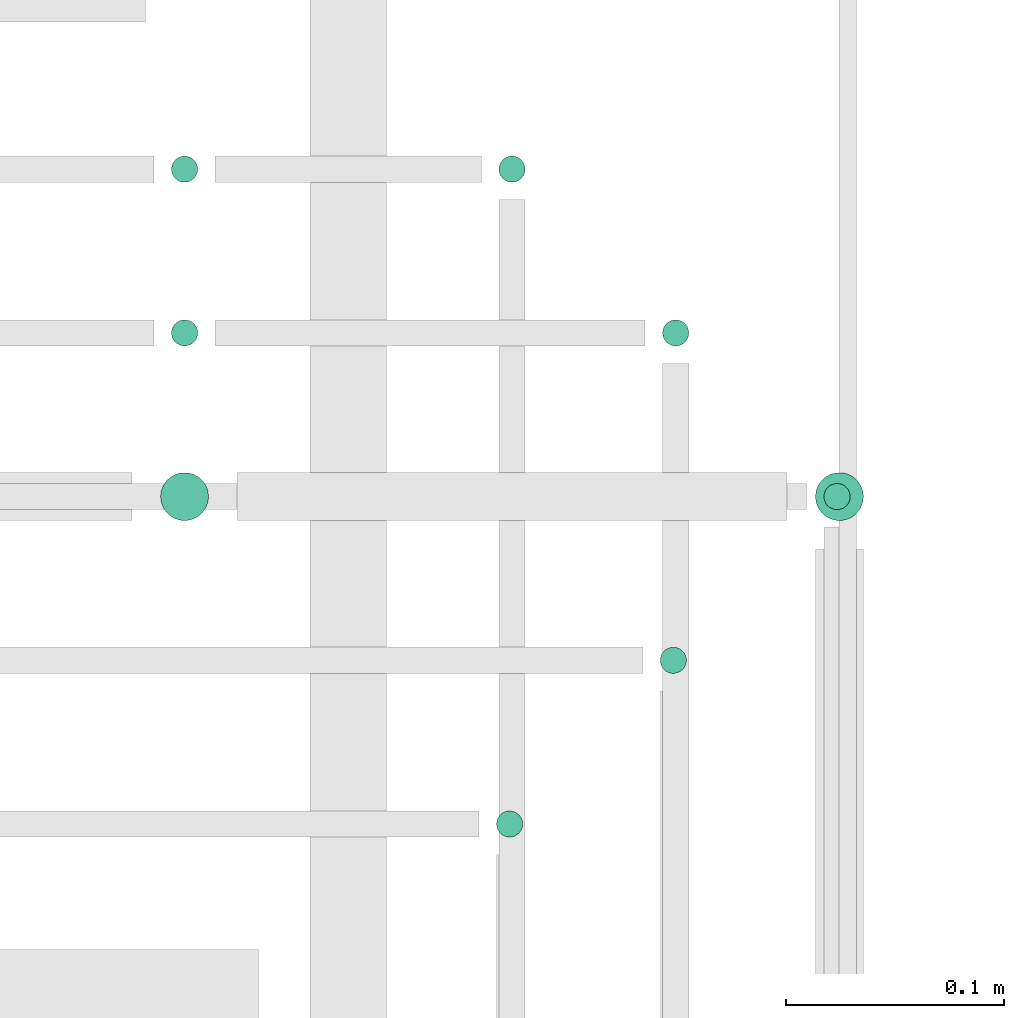
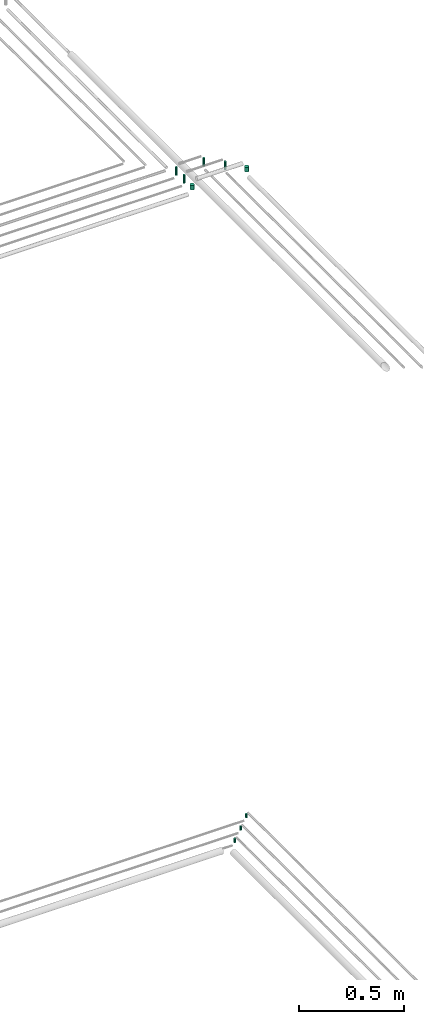
# One storey, part 317 of 331: 9 flow segments.
"""IFC2X3 building model written with IfcOpenShell, lengths in millimetres."""

from ifc_helpers import new_model, entity, si_unit, converted_unit, derived_unit, direction, frame, frame_2d, origin, origin_2d_with_axis, place, context, subcontext, project, spatial, circle, extrude, type_object, element, save


model = new_model("IFC2X3")

# Units and contexts
model_context = context("Model", 3, precision=0.01, world=origin(), true_north=direction((6.12303176911189e-17, 1.0)))
body_context = subcontext(model_context, "Body", "Model", "MODEL_VIEW")
ifc_project = project(units=[si_unit("LENGTHUNIT", "METRE", prefix="MILLI"), si_unit("AREAUNIT", "SQUARE_METRE"), si_unit("VOLUMEUNIT", "CUBIC_METRE"), converted_unit("PLANEANGLEUNIT", "DEGREE", entity("IfcRatioMeasure", 0.0174532925199433), si_unit("PLANEANGLEUNIT", "RADIAN"), dimensions=[0, 0, 0, 0, 0, 0, 0]), si_unit("MASSUNIT", "GRAM", prefix="KILO"), derived_unit("MASSDENSITYUNIT", [(si_unit("MASSUNIT", "GRAM", prefix="KILO"), 1), (si_unit("LENGTHUNIT", "METRE"), -3)]), derived_unit("MOMENTOFINERTIAUNIT", [(si_unit("LENGTHUNIT", "METRE"), 4)]), si_unit("TIMEUNIT", "SECOND"), si_unit("FREQUENCYUNIT", "HERTZ"), si_unit("THERMODYNAMICTEMPERATUREUNIT", "DEGREE_CELSIUS"), derived_unit("THERMALTRANSMITTANCEUNIT", [(si_unit("MASSUNIT", "GRAM", prefix="KILO"), 1), (si_unit("THERMODYNAMICTEMPERATUREUNIT", "KELVIN"), -1), (si_unit("TIMEUNIT", "SECOND"), -3)]), derived_unit("VOLUMETRICFLOWRATEUNIT", [(si_unit("LENGTHUNIT", "METRE"), 3), (si_unit("TIMEUNIT", "SECOND"), -1)]), derived_unit("MASSFLOWRATEUNIT", [(si_unit("MASSUNIT", "GRAM", prefix="KILO"), 1), (si_unit("TIMEUNIT", "SECOND"), -1)]), derived_unit("ROTATIONALFREQUENCYUNIT", [(si_unit("TIMEUNIT", "SECOND"), -1)]), si_unit("ELECTRICCURRENTUNIT", "AMPERE"), si_unit("ELECTRICVOLTAGEUNIT", "VOLT"), si_unit("POWERUNIT", "WATT"), si_unit("FORCEUNIT", "NEWTON", prefix="KILO"), si_unit("ILLUMINANCEUNIT", "LUX"), si_unit("LUMINOUSFLUXUNIT", "LUMEN"), si_unit("LUMINOUSINTENSITYUNIT", "CANDELA"), derived_unit("USERDEFINED", [(si_unit("MASSUNIT", "GRAM", prefix="KILO"), -1), (si_unit("LENGTHUNIT", "METRE"), -2), (si_unit("TIMEUNIT", "SECOND"), 3), (si_unit("LUMINOUSFLUXUNIT", "LUMEN"), 1)]), derived_unit("LINEARVELOCITYUNIT", [(si_unit("LENGTHUNIT", "METRE"), 1), (si_unit("TIMEUNIT", "SECOND"), -1)]), si_unit("PRESSUREUNIT", "PASCAL"), derived_unit("USERDEFINED", [(si_unit("LENGTHUNIT", "METRE"), -2), (si_unit("MASSUNIT", "GRAM", prefix="KILO"), 1), (si_unit("TIMEUNIT", "SECOND"), -2)]), derived_unit("LINEARFORCEUNIT", [(si_unit("MASSUNIT", "GRAM", prefix="KILO"), 1), (si_unit("LENGTHUNIT", "METRE"), 1), (si_unit("TIMEUNIT", "SECOND"), -2), (si_unit("LENGTHUNIT", "METRE"), -1)]), derived_unit("PLANARFORCEUNIT", [(si_unit("MASSUNIT", "GRAM", prefix="KILO"), 1), (si_unit("LENGTHUNIT", "METRE"), 1), (si_unit("TIMEUNIT", "SECOND"), -2), (si_unit("LENGTHUNIT", "METRE"), -2)])], contexts=[model_context])

# Site, building, storey
site_placement = place(None, frame((0.0, -0.00077364408347762, 0.0)))
site = spatial("IfcSite", under=ifc_project, at=site_placement, CompositionType="ELEMENT")
building_placement = place(site_placement, origin())
building = spatial("IfcBuilding", under=site, at=building_placement, CompositionType="ELEMENT")
storey_placement = place(building_placement, origin())
storey = spatial("IfcBuildingStorey", under=building, at=storey_placement, CompositionType="ELEMENT", Elevation=0.0)

# Flow segments
pipe_segment_type = type_object("IfcPipeSegmentType", PredefinedType="NOTDEFINED")
flow_segment_1_placement = place(storey_placement, frame((62062.513259057, 14117.4047277641, 14714.0)))
element("IfcFlowSegment", 1, at=flow_segment_1_placement, inside=storey, type_object=pipe_segment_type, context=body_context, shape_type="SweptSolid", body=[
    extrude(circle(Radius=6.0, at=frame_2d((0.0, -2.16573425859679e-12), x_axis=(1.0, 0.0))), frame((7.59527223591454, 7.59527223591887, 0.0)), (0.0, 0.0, 1.0), 22.000000000008),
])
flow_segment_2_placement = place(storey_placement, frame((62137.513259057, 14192.4047277641, 14714.0)))
element("IfcFlowSegment", 2, at=flow_segment_2_placement, inside=storey, type_object=pipe_segment_type, context=body_context, shape_type="SweptSolid", body=[
    extrude(circle(Radius=6.0, at=origin_2d_with_axis()), frame((7.59527223591454, 7.5952722359167, 0.0)), (0.0, 0.0, 1.0), 22.000000000008),
])
flow_segment_3_placement = place(storey_placement, frame((62212.5132590569, 14267.4047277641, 14714.0)))
element("IfcFlowSegment", 3, at=flow_segment_3_placement, inside=storey, type_object=pipe_segment_type, context=body_context, shape_type="SweptSolid", body=[
    extrude(circle(Radius=6.0, at=origin_2d_with_axis()), frame((7.59527223591454, 7.5952722359167, 0.0)), (0.0, 0.0, 1.0), 22.0000000000015),
])
flow_segment_4_placement = place(storey_placement, frame((62208.5947663298, 14262.4047277641, 18474.0)))
element("IfcFlowSegment", 4, at=flow_segment_4_placement, inside=storey, type_object=pipe_segment_type, context=body_context, shape_type="SweptSolid", body=[
    extrude(circle(Radius=11.0, at=origin_2d_with_axis()), frame((12.5952722359134, 12.5952722359156, 0.0), z_axis=(0.0, 0.0, 1.0), x_axis=(-1.0, 0.0, 0.0)), (0.0, 0.0, 1.0), 27.0000000000935),
])
flow_segment_5_placement = place(storey_placement, frame((62138.5947663298, 14342.4047277641, 18464.0)))
element("IfcFlowSegment", 5, at=flow_segment_5_placement, inside=storey, type_object=pipe_segment_type, context=body_context, shape_type="SweptSolid", body=[
    extrude(circle(Radius=6.0, at=origin_2d_with_axis()), frame((7.59527223591454, 7.5952722359167, 0.0), z_axis=(0.0, 0.0, 1.0), x_axis=(-1.0, 0.0, 0.0)), (0.0, 0.0, 1.0), 47.0000000000954),
])
flow_segment_6_placement = place(storey_placement, frame((62063.5947663297, 14417.4047277641, 18464.0)))
element("IfcFlowSegment", 6, at=flow_segment_6_placement, inside=storey, type_object=pipe_segment_type, context=body_context, shape_type="SweptSolid", body=[
    extrude(circle(Radius=6.0, at=frame_2d((0.0, 2.16573425859679e-12), x_axis=(1.0, 0.0))), frame((7.59527223591454, 7.59527223591887, 0.0), z_axis=(0.0, 0.0, 1.0), x_axis=(-1.0, 0.0, 0.0)), (0.0, 0.0, 1.0), 47.0000000000673),
])
flow_segment_7_placement = place(storey_placement, frame((61908.5947663298, 14262.4047277641, 18474.0)))
element("IfcFlowSegment", 7, at=flow_segment_7_placement, inside=storey, type_object=pipe_segment_type, context=body_context, shape_type="SweptSolid", body=[
    extrude(circle(Radius=11.0, at=origin_2d_with_axis()), frame((12.5952722359134, 12.5952722359156, 0.0)), (0.0, 0.0, 1.0), 27.0000000000198),
])
flow_segment_8_placement = place(storey_placement, frame((61913.5947663298, 14342.4047277641, 18464.0)))
element("IfcFlowSegment", 8, at=flow_segment_8_placement, inside=storey, type_object=pipe_segment_type, context=body_context, shape_type="SweptSolid", body=[
    extrude(circle(Radius=6.0, at=origin_2d_with_axis()), frame((7.59527223591454, 7.5952722359167, 0.0)), (0.0, 0.0, 1.0), 47.0000000000153),
])
flow_segment_9_placement = place(storey_placement, frame((61913.5947663298, 14417.4047277641, 18464.0)))
element("IfcFlowSegment", 9, at=flow_segment_9_placement, inside=storey, type_object=pipe_segment_type, context=body_context, shape_type="SweptSolid", body=[
    extrude(circle(Radius=6.0, at=origin_2d_with_axis()), frame((7.59527223591454, 7.5952722359167, 0.0)), (0.0, 0.0, 1.0), 47.0000000000175),
])

save(model, "model.ifc")
